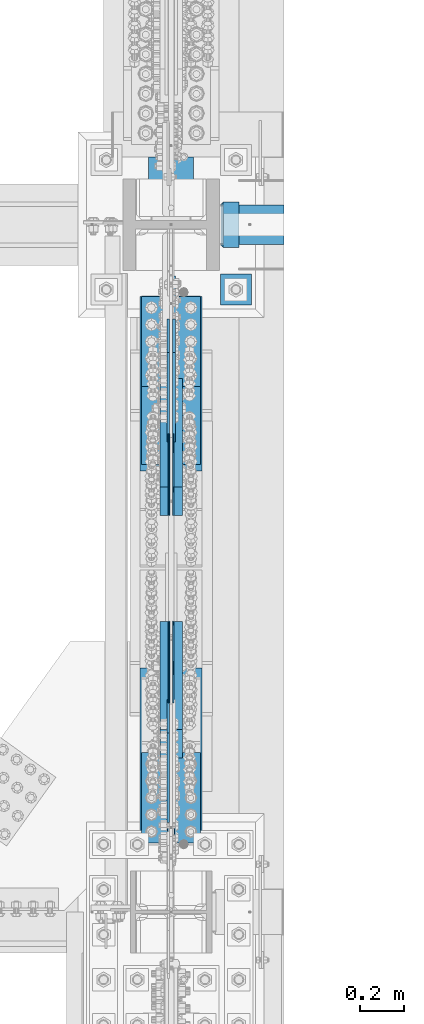
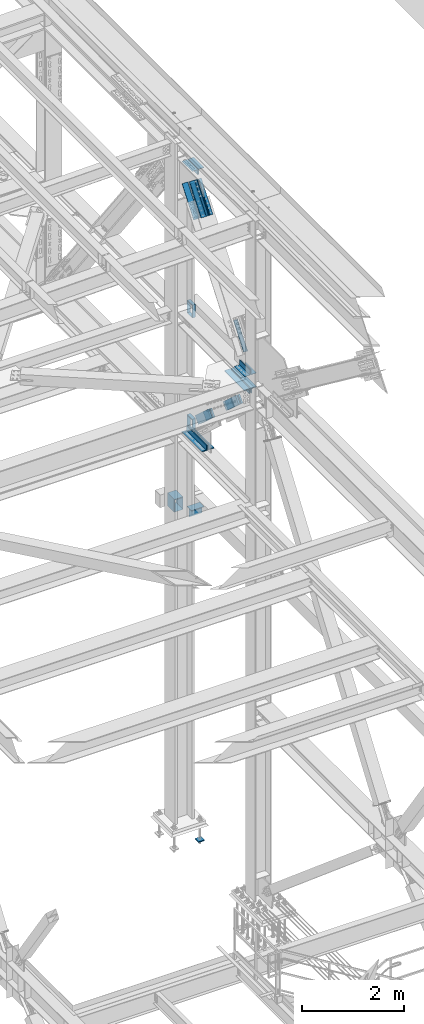
# One storey, part 2592 of 3843: 15 members, 13 beams, 12 elements without a shape of their own.
"""IFC2X3 building model written with IfcOpenShell, lengths in millimetres."""

from ifc_helpers import new_model, si_unit, frame, origin_with_axes, place, context, subcontext, project, spatial, faceted_brep, material, type_object, element, aggregate, save


model = new_model("IFC2X3")

# Units and contexts
model_context = context("Model", 3, precision=1e-05, world=origin_with_axes())
body_context = subcontext(model_context, "Body", "Model", "MODEL_VIEW")
ifc_project = project(units=[si_unit("LENGTHUNIT", "METRE", prefix="MILLI"), si_unit("AREAUNIT", "SQUARE_METRE"), si_unit("VOLUMEUNIT", "CUBIC_METRE"), si_unit("MASSUNIT", "GRAM", prefix="KILO"), si_unit("TIMEUNIT", "SECOND"), si_unit("PLANEANGLEUNIT", "RADIAN"), si_unit("SOLIDANGLEUNIT", "STERADIAN"), si_unit("THERMODYNAMICTEMPERATUREUNIT", "DEGREE_CELSIUS"), si_unit("LUMINOUSINTENSITYUNIT", "LUMEN")], contexts=[model_context])

# Site, building, storey
site_placement = place(None, origin_with_axes())
site = spatial("IfcSite", under=ifc_project, at=site_placement, CompositionType="ELEMENT")
building_placement = place(site_placement, origin_with_axes())
building = spatial("IfcBuilding", under=site, at=building_placement, Name="Undefined", CompositionType="ELEMENT")
storey_placement = place(building_placement, origin_with_axes())
storey = spatial("IfcBuildingStorey", under=building, at=storey_placement, Name="Undefined", CompositionType="ELEMENT", Elevation=0.0)

# Assembly, beams
assembly_1_placement = place(storey_placement, origin_with_axes())
assembly_1 = element("IfcElementAssembly", 1, at=assembly_1_placement, inside=storey, Name="COLUMN", AssemblyPlace="NOTDEFINED", PredefinedType="RIGID_FRAME")
ifc_material_1 = material(Name="STEEL/A992")
beam_type_1 = type_object("IfcBeamType", Name="WT8X18", PredefinedType="NOTDEFINED")
beam_1_placement = place(assembly_1_placement, frame((85866.2875, 28714.7, 37339.5875), z_axis=(0.0, 0.0, 1.0), x_axis=(1.0, 0.0, 0.0)))
beam_1 = element("IfcBeam", 2, at=beam_1_placement, type_object=beam_type_1, material=ifc_material_1, Name="BEAM", ObjectType="WT8X18", context=body_context, shape_type="Brep", body=[
    faceted_brep([(-1.45519152283669e-11, 3.96875, -100.012499999997), (-1.45519152283669e-11, 3.96875, 88.9000000000015), (290.512438964855, 3.96875000066939, 88.9000000000015), (290.512438964855, 3.96875000066939, -100.012499999997), (-2.18278728425503e-10, 88.8999999999942, 88.9000000000015), (290.512438964652, 88.9000000006781, 88.9000000000015), (-2.18278728425503e-10, 88.8999999999942, 100.012499999997), (290.512438964652, 88.9000000006781, 100.012499999997), (2.03726813197136e-10, -88.8999999999942, 100.012499999997), (290.512438965074, -88.8999999993248, 100.012499999997), (2.03726813197136e-10, -88.8999999999942, 88.9000000000015), (290.512438965074, -88.8999999993248, 88.9000000000015), (0.0, -3.96875, 88.9000000000015), (290.51243896487, -3.96874999933061, 88.9000000000015), (0.0, -3.96875, -100.012499999997), (290.51243896487, -3.96874999933061, -100.012499999997)], [[[0, 1, 2, 3]], [[1, 4, 5, 2]], [[4, 6, 7, 5]], [[6, 8, 9, 7]], [[8, 10, 11, 9]], [[10, 12, 13, 11]], [[12, 14, 15, 13]], [[14, 0, 3, 15]], [[5, 7, 9, 11, 13, 15, 3, 2]], [[14, 12, 10, 8, 6, 4, 1, 0]]]),
])
ifc_material_2 = material()
beam_type_2 = type_object("IfcBeamType", Name="HSS12X8X3/8", PredefinedType="NOTDEFINED")
beam_2_placement = place(assembly_1_placement, frame((85648.8, 29019.5, 37592.0), z_axis=(0.0, 0.0, 1.0), x_axis=(0.0, -1.0, 0.0)))
beam_2 = element("IfcBeam", 3, at=beam_2_placement, type_object=beam_type_2, material=ifc_material_2, Name="BEAM", ObjectType="HSS12X8X3/8", context=body_context, shape_type="Brep", body=[
    faceted_brep([(280.193750000006, 92.0749999999971, 142.875), (280.193750000006, 92.0749999999971, -142.875), (270.668750000012, 101.600000000006, -152.400000000001), (270.668750000012, 101.600000000006, 152.400000000001), (280.193750000006, -92.0749999999971, -142.875), (270.668750000012, -101.600000000006, -152.400000000001), (280.193750000006, -92.0749999999971, 142.875), (270.668750000012, -101.600000000006, 152.400000000001), (0.0, 92.0749999999971, 142.875), (0.0, 92.0749999999971, -142.875), (0.0, -92.0749999999971, 142.875), (0.0, -92.0749999999971, -142.875), (0.0, -101.600000000006, -152.400000000001), (0.0, -101.600000000006, 152.400000000001), (0.0, 101.600000000006, 152.400000000001), (0.0, 101.600000000006, -152.400000000001)], [[[0, 1, 2, 3]], [[4, 5, 2, 1]], [[6, 7, 5, 4]], [[8, 9, 1, 0]], [[10, 8, 0, 6]], [[11, 10, 6, 4]], [[9, 11, 4, 1]], [[12, 13, 14, 15], [8, 10, 11, 9]], [[15, 14, 3, 2]], [[12, 15, 2, 5]], [[13, 12, 5, 7]], [[14, 13, 7, 3]], [[0, 3, 7, 6]]]),
])
beam_3_placement = place(assembly_1_placement, frame((85866.2875006762, 28714.7, 39477.95), z_axis=(0.0, 0.0, 1.0), x_axis=(1.0, 0.0, 0.0)))
beam_3 = element("IfcBeam", 4, at=beam_3_placement, type_object=beam_type_2, material=ifc_material_2, Name="BEAM", ObjectType="HSS12X8X3/8", context=body_context, shape_type="Brep", body=[
    faceted_brep([(15.8750001309381, 101.600000000006, 152.399999999972), (15.8749984899478, 101.600000000006, -152.400000000031), (6.35000000002037, 92.0749999999971, -142.875), (6.35000000002037, 92.0749999999971, 142.875), (15.8749984899478, -101.600000000006, -152.400000000031), (6.35000000002037, -92.0749999999971, -142.875), (15.8750001044536, -101.600000052975, 152.399999973481), (6.35000000002037, -92.0749999999971, 142.875), (87.3124999991851, -101.600000000006, 152.39999999987), (87.3124999991851, 101.600000000006, 152.39999999987), (87.312500000975, -101.600000000006, -152.400000000125), (87.312500000975, 101.600000000006, -152.400000000125), (87.3124999992433, -92.0749999999971, 142.874999999876), (87.3124999992433, 92.0749999999971, 142.874999999876), (87.3125000009022, 92.0749999999971, -142.875000000124), (87.3125000009022, -92.0749999999971, -142.875000000124)], [[[0, 1, 2, 3]], [[4, 5, 2, 1]], [[6, 7, 5, 4]], [[8, 9, 0, 6]], [[10, 8, 6, 4]], [[11, 10, 4, 1]], [[9, 11, 1, 0]], [[8, 10, 11, 9], [12, 13, 14, 15]], [[14, 13, 3, 2]], [[15, 14, 2, 5]], [[12, 15, 5, 7]], [[13, 12, 7, 3]], [[0, 3, 7, 6]]]),
])
beam_4_placement = place(assembly_1_placement, frame((85866.2875007094, 28714.7, 42214.8), z_axis=(0.0, 0.0, 1.0), x_axis=(1.0, 0.0, 0.0)))
beam_4 = element("IfcBeam", 5, at=beam_4_placement, type_object=beam_type_2, material=ifc_material_2, Name="BEAM", ObjectType="HSS12X8X3/8", context=body_context, shape_type="Brep", body=[
    faceted_brep([(15.8750001309381, 101.600000000006, 152.399999999972), (15.8749984899478, 101.600000000006, -152.400000000031), (6.35000000002037, 92.0749999999971, -142.875), (6.35000000002037, 92.0749999999971, 142.875), (15.8749984899478, -101.600000000006, -152.400000000031), (6.35000000002037, -92.0749999999971, -142.875), (15.8750001044536, -101.600000052975, 152.399999973481), (6.35000000002037, -92.0749999999971, 142.875), (87.3124999991851, -101.600000000006, 152.39999999987), (87.3124999991851, 101.600000000006, 152.39999999987), (87.312500000975, -101.600000000006, -152.400000000125), (87.312500000975, 101.600000000006, -152.400000000125), (87.3124999992433, -92.0749999999971, 142.874999999876), (87.3124999992433, 92.0749999999971, 142.874999999876), (87.3125000009022, 92.0749999999971, -142.875000000124), (87.3125000009022, -92.0749999999971, -142.875000000124)], [[[0, 1, 2, 3]], [[4, 5, 2, 1]], [[6, 7, 5, 4]], [[8, 9, 0, 6]], [[10, 8, 6, 4]], [[11, 10, 4, 1]], [[9, 11, 1, 0]], [[8, 10, 11, 9], [12, 13, 14, 15]], [[14, 13, 3, 2]], [[15, 14, 2, 5]], [[12, 15, 5, 7]], [[13, 12, 7, 3]], [[0, 3, 7, 6]]]),
])
aggregate(assembly_1, [beam_1, beam_2, beam_3, beam_4])

# Assembly, members
assembly_2_placement = place(storey_placement, origin_with_axes())
assembly_2 = element("IfcElementAssembly", 6, at=assembly_2_placement, inside=storey, AssemblyPlace="NOTDEFINED", PredefinedType="RIGID_FRAME")
ifc_material_3 = material(Name="STEEL/A572-50")
member_type_1 = type_object("IfcMemberType", PredefinedType="NOTDEFINED")
member_1_placement = place(assembly_2_placement, frame((85680.5500000244, 27956.6025375945, 40116.8944140801), z_axis=(0.0, -0.672974507774428, -0.73966567575207), x_axis=(0.0, -0.739665675752071, 0.672974507774427)))
member_1 = element("IfcMember", 7, at=member_1_placement, type_object=member_type_1, material=ifc_material_3, Name="PLATE", context=body_context, shape_type="Brep", body=[
    faceted_brep([(1.16415321826935e-10, 19.0500000000029, -95.2500000001601), (-1.16415321826935e-10, 19.0500000000029, 95.2500000001601), (660.400000008245, 19.0500000000029, 95.2500000025429), (660.400000007954, 19.0500000000029, -95.2499999980901), (-1.16415321826935e-10, -19.0500000000029, 95.2500000001601), (660.400000008245, -19.0500000000029, 95.2500000025429), (1.16415321826935e-10, -19.0500000000029, -95.2500000001601), (660.400000007954, -19.0500000000029, -95.2499999980901)], [[[0, 1, 2, 3]], [[1, 4, 5, 2]], [[4, 6, 7, 5]], [[6, 0, 3, 7]], [[5, 7, 3, 2]], [[6, 4, 1, 0]]]),
])
member_2_placement = place(assembly_2_placement, frame((85617.0500000244, 27956.6025375945, 40116.8944140801), z_axis=(0.0, -0.672974507774428, -0.73966567575207), x_axis=(0.0, -0.739665675752071, 0.672974507774427)))
member_2 = element("IfcMember", 8, at=member_2_placement, type_object=member_type_1, material=ifc_material_3, Name="PLATE", context=body_context, shape_type="Brep", body=[
    faceted_brep([(1.16415321826935e-10, 19.0500000000029, -95.2500000001601), (-1.16415321826935e-10, 19.0500000000029, 95.2500000001601), (660.400000008245, 19.0500000000029, 95.2500000025429), (660.400000007954, 19.0500000000029, -95.2499999980901), (-1.16415321826935e-10, -19.0500000000029, 95.2500000001601), (660.400000008245, -19.0500000000029, 95.2500000025429), (1.16415321826935e-10, -19.0500000000029, -95.2500000001601), (660.400000007954, -19.0500000000029, -95.2499999980901)], [[[0, 1, 2, 3]], [[1, 4, 5, 2]], [[4, 6, 7, 5]], [[6, 0, 3, 7]], [[5, 7, 3, 2]], [[6, 4, 1, 0]]]),
])
member_3_placement = place(assembly_2_placement, frame((85680.5500000244, 26374.2859692125, 41556.5430940823), z_axis=(0.0, 0.672974507774428, 0.73966567575207), x_axis=(0.0, 0.739665675752074, -0.672974507774424)))
member_3 = element("IfcMember", 9, at=member_3_placement, type_object=member_type_1, material=ifc_material_3, Name="PLATE", context=body_context, shape_type="Brep", body=[
    faceted_brep([(1.16415321826935e-10, 19.0500000000029, -95.2500000001601), (-1.16415321826935e-10, 19.0500000000029, 95.2500000001601), (660.400000008245, 19.0500000000029, 95.2500000025429), (660.400000007954, 19.0500000000029, -95.2499999980901), (-1.16415321826935e-10, -19.0500000000029, 95.2500000001601), (660.400000008245, -19.0500000000029, 95.2500000025429), (1.16415321826935e-10, -19.0500000000029, -95.2500000001601), (660.400000007954, -19.0500000000029, -95.2499999980901)], [[[0, 1, 2, 3]], [[1, 4, 5, 2]], [[4, 6, 7, 5]], [[6, 0, 3, 7]], [[5, 7, 3, 2]], [[6, 4, 1, 0]]]),
])
member_4_placement = place(assembly_2_placement, frame((85617.0500000244, 26374.2859692125, 41556.5430940823), z_axis=(0.0, 0.672974507774428, 0.73966567575207), x_axis=(0.0, 0.739665675752074, -0.672974507774424)))
member_4 = element("IfcMember", 10, at=member_4_placement, type_object=member_type_1, material=ifc_material_3, Name="PLATE", context=body_context, shape_type="Brep", body=[
    faceted_brep([(1.16415321826935e-10, 19.0500000000029, -95.2500000001601), (-1.16415321826935e-10, 19.0500000000029, 95.2500000001601), (660.400000008245, 19.0500000000029, 95.2500000025429), (660.400000007954, 19.0500000000029, -95.2499999980901), (-1.16415321826935e-10, -19.0500000000029, 95.2500000001601), (660.400000008245, -19.0500000000029, 95.2500000025429), (1.16415321826935e-10, -19.0500000000029, -95.2500000001601), (660.400000007954, -19.0500000000029, -95.2499999980901)], [[[0, 1, 2, 3]], [[1, 4, 5, 2]], [[4, 6, 7, 5]], [[6, 0, 3, 7]], [[5, 7, 3, 2]], [[6, 4, 1, 0]]]),
])

assembly_3_placement = place(storey_placement, origin_with_axes())
assembly_3 = element("IfcElementAssembly", 11, at=assembly_3_placement, inside=storey, AssemblyPlace="NOTDEFINED", PredefinedType="RIGID_FRAME")
member_type_2 = type_object("IfcMemberType", Name="L5X5X1/2", PredefinedType="NOTDEFINED")
member_5_placement = place(assembly_3_placement, frame((85718.6500000203, 28432.895159196, 45510.7300220874), z_axis=(0.0, 0.792438093282071, -0.609952349217114), x_axis=(0.0, -0.609952349217112, -0.792438093282072)))
member_5 = element("IfcMember", 12, at=member_5_placement, type_object=member_type_2, material=ifc_material_3, Name="ANGLE", ObjectType="L5X5X1/2", context=body_context, shape_type="Brep", body=[
    faceted_brep([(-1.01863406598568e-10, 63.5, -63.5000000002037), (1.01863406598568e-10, 63.5, 63.5000000002074), (749.300000016152, 63.5, 63.4999999992142), (749.300000016028, 63.5, -63.5000000006548), (1.01863406598568e-10, 50.8000000000029, 63.5000000002074), (749.300000016152, 50.8000000000029, 63.4999999992142), (0.0, 50.8000000000029, -50.8000000000029), (749.30000001605, 50.8000000000029, -50.8000000006577), (-7.27595761418343e-11, -63.5, -50.8000000001666), (749.30000001605, -63.5, -50.8000000006577), (-1.01863406598568e-10, -63.5, -63.5000000002037), (749.300000016028, -63.5, -63.5000000006548)], [[[0, 1, 2, 3]], [[1, 4, 5, 2]], [[4, 6, 7, 5]], [[6, 8, 9, 7]], [[8, 10, 11, 9]], [[10, 0, 3, 11]], [[5, 7, 9, 11, 3, 2]], [[10, 8, 6, 4, 1, 0]]]),
])
member_6_placement = place(assembly_3_placement, frame((85718.6500000203, 27593.4272401154, 45211.3191625252), z_axis=(0.0, -0.79243809328207, 0.609952349217115), x_axis=(0.0, 0.60995234921711, 0.792438093282074)))
member_6 = element("IfcMember", 13, at=member_6_placement, type_object=member_type_2, material=ifc_material_3, Name="ANGLE", ObjectType="L5X5X1/2", context=body_context, shape_type="Brep", body=[
    faceted_brep([(-1.01863406598568e-10, 63.5, -63.5000000002037), (1.01863406598568e-10, 63.5, 63.5000000002074), (749.300000016152, 63.5, 63.4999999992142), (749.300000016028, 63.5, -63.5000000006548), (1.01863406598568e-10, 50.8000000000029, 63.5000000002074), (749.300000016152, 50.8000000000029, 63.4999999992142), (0.0, 50.8000000000029, -50.8000000000029), (749.30000001605, 50.8000000000029, -50.8000000006577), (-7.27595761418343e-11, -63.5, -50.8000000001666), (749.30000001605, -63.5, -50.8000000006577), (-1.01863406598568e-10, -63.5, -63.5000000002037), (749.300000016028, -63.5, -63.5000000006548)], [[[0, 1, 2, 3]], [[1, 4, 5, 2]], [[4, 6, 7, 5]], [[6, 8, 9, 7]], [[8, 10, 11, 9]], [[10, 0, 3, 11]], [[5, 7, 9, 11, 3, 2]], [[10, 8, 6, 4, 1, 0]]]),
])
member_7_placement = place(assembly_3_placement, frame((85578.9500000203, 27975.8578639315, 44916.956158795), z_axis=(0.0, 0.792438093282071, -0.609952349217114), x_axis=(0.0, 0.60995234921711, 0.792438093282074)))
member_7 = element("IfcMember", 14, at=member_7_placement, type_object=member_type_2, material=ifc_material_3, Name="ANGLE", ObjectType="L5X5X1/2", context=body_context, shape_type="Brep", body=[
    faceted_brep([(-1.01863406598568e-10, 63.5, -63.5000000002037), (1.01863406598568e-10, 63.5, 63.5000000002074), (749.300000016152, 63.5, 63.4999999992142), (749.300000016028, 63.5, -63.5000000006548), (1.01863406598568e-10, 50.8000000000029, 63.5000000002074), (749.300000016152, 50.8000000000029, 63.4999999992142), (0.0, 50.8000000000029, -50.8000000000029), (749.30000001605, 50.8000000000029, -50.8000000006577), (-7.27595761418343e-11, -63.5, -50.8000000001666), (749.30000001605, -63.5, -50.8000000006577), (-1.01863406598568e-10, -63.5, -63.5000000002037), (749.300000016028, -63.5, -63.5000000006548)], [[[0, 1, 2, 3]], [[1, 4, 5, 2]], [[4, 6, 7, 5]], [[6, 8, 9, 7]], [[8, 10, 11, 9]], [[10, 0, 3, 11]], [[5, 7, 9, 11, 3, 2]], [[10, 8, 6, 4, 1, 0]]]),
])
member_8_placement = place(assembly_3_placement, frame((85578.9500000203, 28050.4645353799, 45805.0930258176), z_axis=(0.0, -0.79243809328207, 0.609952349217115), x_axis=(0.0, -0.609952349217112, -0.792438093282072)))
member_8 = element("IfcMember", 15, at=member_8_placement, type_object=member_type_2, material=ifc_material_3, Name="ANGLE", ObjectType="L5X5X1/2", context=body_context, shape_type="Brep", body=[
    faceted_brep([(-1.01863406598568e-10, 63.5, -63.5000000002037), (1.01863406598568e-10, 63.5, 63.5000000002074), (749.300000016152, 63.5, 63.4999999992142), (749.300000016028, 63.5, -63.5000000006548), (1.01863406598568e-10, 50.8000000000029, 63.5000000002074), (749.300000016152, 50.8000000000029, 63.4999999992142), (0.0, 50.8000000000029, -50.8000000000029), (749.30000001605, 50.8000000000029, -50.8000000006577), (-7.27595761418343e-11, -63.5, -50.8000000001666), (749.30000001605, -63.5, -50.8000000006577), (-1.01863406598568e-10, -63.5, -63.5000000002037), (749.300000016028, -63.5, -63.5000000006548)], [[[0, 1, 2, 3]], [[1, 4, 5, 2]], [[4, 6, 7, 5]], [[6, 8, 9, 7]], [[8, 10, 11, 9]], [[10, 0, 3, 11]], [[5, 7, 9, 11, 3, 2]], [[10, 8, 6, 4, 1, 0]]]),
])

# Member
member_type_3 = type_object("IfcMemberType", PredefinedType="NOTDEFINED")
member_9_placement = place(assembly_2_placement, frame((85658.3250000244, 27707.6680544176, 40343.3839846709), z_axis=(0.0, -0.672974507774428, -0.73966567575207), x_axis=(0.0, -0.739665675752071, 0.672974507774427)))
member_9 = element("IfcMember", 16, at=member_9_placement, type_object=member_type_3, material=ifc_material_3, Name="PLATE", context=body_context, shape_type="Brep", body=[
    faceted_brep([(0.0, 3.17499999999927, -95.25), (-2.44140610448085e-05, 3.17500000000291, 95.2499999999927), (323.850000004109, 3.17500000000291, 95.2500000014152), (323.850000003833, 3.17500000000291, -95.2499999992106), (0.0, -3.17499999999927, 95.25), (323.850000004109, -3.17500000000291, 95.2500000014152), (0.0, -3.17499999999927, -95.25), (323.850000003833, -3.17500000000291, -95.2499999992106)], [[[0, 1, 2, 3]], [[1, 4, 5, 2]], [[4, 6, 7, 5]], [[6, 0, 3, 7]], [[5, 7, 3, 2]], [[6, 4, 1, 0]]]),
])

member_10_placement = place(assembly_2_placement, frame((85639.2750000244, 27707.6680544176, 40343.3839846709), z_axis=(0.0, -0.672974507774428, -0.73966567575207), x_axis=(0.0, -0.739665675752071, 0.672974507774427)))
member_10 = element("IfcMember", 17, at=member_10_placement, type_object=member_type_3, material=ifc_material_3, Name="PLATE", context=body_context, shape_type="Brep", body=[
    faceted_brep([(0.0, 3.17499999999927, -95.25), (-2.44140610448085e-05, 3.17500000000291, 95.2499999999927), (323.850000004109, 3.17500000000291, 95.2500000014152), (323.850000003833, 3.17500000000291, -95.2499999992106), (0.0, -3.17499999999927, 95.25), (323.850000004109, -3.17500000000291, 95.2500000014152), (0.0, -3.17499999999927, -95.25), (323.850000003833, -3.17500000000291, -95.2499999992106)], [[[0, 1, 2, 3]], [[1, 4, 5, 2]], [[4, 6, 7, 5]], [[6, 0, 3, 7]], [[5, 7, 3, 2]], [[6, 4, 1, 0]]]),
])

member_11_placement = place(assembly_2_placement, frame((85658.3250000244, 26623.2204523893, 41330.0535234915), z_axis=(0.0, 0.672974507774428, 0.73966567575207), x_axis=(0.0, 0.739665675752074, -0.672974507774424)))
member_11 = element("IfcMember", 18, at=member_11_placement, type_object=member_type_3, material=ifc_material_3, Name="PLATE", context=body_context, shape_type="Brep", body=[
    faceted_brep([(0.0, 3.17499999999927, -95.25), (-2.44140610448085e-05, 3.17500000000291, 95.2499999999927), (323.850000004109, 3.17500000000291, 95.2500000014152), (323.850000003833, 3.17500000000291, -95.2499999992106), (0.0, -3.17499999999927, 95.25), (323.850000004109, -3.17500000000291, 95.2500000014152), (0.0, -3.17499999999927, -95.25), (323.850000003833, -3.17500000000291, -95.2499999992106)], [[[0, 1, 2, 3]], [[1, 4, 5, 2]], [[4, 6, 7, 5]], [[6, 0, 3, 7]], [[5, 7, 3, 2]], [[6, 4, 1, 0]]]),
])

member_12_placement = place(assembly_2_placement, frame((85639.2750000244, 26623.2204523893, 41330.0535234915), z_axis=(0.0, 0.672974507774428, 0.73966567575207), x_axis=(0.0, 0.739665675752074, -0.672974507774424)))
member_12 = element("IfcMember", 19, at=member_12_placement, type_object=member_type_3, material=ifc_material_3, Name="PLATE", context=body_context, shape_type="Brep", body=[
    faceted_brep([(0.0, 3.17499999999927, -95.25), (-2.44140610448085e-05, 3.17500000000291, 95.2499999999927), (323.850000004109, 3.17500000000291, 95.2500000014152), (323.850000003833, 3.17500000000291, -95.2499999992106), (0.0, -3.17499999999927, 95.25), (323.850000004109, -3.17500000000291, 95.2500000014152), (0.0, -3.17499999999927, -95.25), (323.850000003833, -3.17500000000291, -95.2499999992106)], [[[0, 1, 2, 3]], [[1, 4, 5, 2]], [[4, 6, 7, 5]], [[6, 0, 3, 7]], [[5, 7, 3, 2]], [[6, 4, 1, 0]]]),
])

aggregate(assembly_2, [member_1, member_9, member_10, member_2, member_3, member_11, member_12, member_4])

# Assembly, beam
assembly_4_placement = place(storey_placement, origin_with_axes())
assembly_4 = element("IfcElementAssembly", 20, at=assembly_4_placement, inside=storey, Name="ANGLE", AssemblyPlace="NOTDEFINED", PredefinedType="RIGID_FRAME")
beam_type_3 = type_object("IfcBeamType", Name="L5X5X3/4", PredefinedType="NOTDEFINED")
beam_5_placement = place(assembly_4_placement, frame((85725.0000000257, 27604.2437499993, 39649.3999999958), z_axis=(0.0, 0.0, 1.0), x_axis=(0.0, 1.0, 0.0)))
beam_5 = element("IfcBeam", 21, at=beam_5_placement, type_object=beam_type_3, material=ifc_material_3, Name="ANGLE", ObjectType="L5X5X3/4", context=body_context, shape_type="Brep", body=[
    faceted_brep([(-1.01863406598568e-10, 63.5, -63.5000000002037), (1.01863406598568e-10, 63.5, 63.5000000002074), (787.399999999994, 63.5, 63.5), (787.399999999994, 63.5, -63.5), (0.0, 44.4499999999971, 63.5), (787.399999999994, 44.4499999999971, 63.5), (-3.63797880709171e-12, 44.4499999999971, -44.4500000000007), (787.399999999994, 44.4499999999971, -44.4499999999971), (0.0, -63.5, -44.4499999999971), (787.399999999994, -63.5, -44.4499999999971), (-1.01863406598568e-10, -63.5, -63.5000000002037), (787.399999999994, -63.5, -63.5)], [[[0, 1, 2, 3]], [[1, 4, 5, 2]], [[4, 6, 7, 5]], [[6, 8, 9, 7]], [[8, 10, 11, 9]], [[10, 0, 3, 11]], [[5, 7, 9, 11, 3, 2]], [[10, 8, 6, 4, 1, 0]]]),
])
aggregate(assembly_4, [beam_5])

assembly_5_placement = place(storey_placement, origin_with_axes())
assembly_5 = element("IfcElementAssembly", 22, at=assembly_5_placement, inside=storey, Name="ANGLE", AssemblyPlace="NOTDEFINED", PredefinedType="RIGID_FRAME")
beam_6_placement = place(assembly_5_placement, frame((85572.6000000232, 28391.6437499993, 39649.3999999963), z_axis=(0.0, 0.0, 1.0), x_axis=(0.0, -1.0, 0.0)))
beam_6 = element("IfcBeam", 23, at=beam_6_placement, type_object=beam_type_3, material=ifc_material_3, Name="ANGLE", ObjectType="L5X5X3/4", context=body_context, shape_type="Brep", body=[
    faceted_brep([(-1.01863406598568e-10, 63.5, -63.5000000002037), (1.01863406598568e-10, 63.5, 63.5000000002074), (787.399999999994, 63.5, 63.5), (787.399999999994, 63.5, -63.5), (0.0, 44.4499999999971, 63.5), (787.399999999994, 44.4499999999971, 63.5), (-3.63797880709171e-12, 44.4499999999971, -44.4500000000007), (787.399999999994, 44.4499999999971, -44.4499999999971), (0.0, -63.5, -44.4499999999971), (787.399999999994, -63.5, -44.4499999999971), (-1.01863406598568e-10, -63.5, -63.5000000002037), (787.399999999994, -63.5, -63.5)], [[[0, 1, 2, 3]], [[1, 4, 5, 2]], [[4, 6, 7, 5]], [[6, 8, 9, 7]], [[8, 10, 11, 9]], [[10, 0, 3, 11]], [[5, 7, 9, 11, 3, 2]], [[10, 8, 6, 4, 1, 0]]]),
])
aggregate(assembly_5, [beam_6])

assembly_6_placement = place(storey_placement, origin_with_axes())
assembly_6 = element("IfcElementAssembly", 24, at=assembly_6_placement, inside=storey, Name="ANGLE", AssemblyPlace="NOTDEFINED", PredefinedType="RIGID_FRAME")
beam_7_placement = place(assembly_6_placement, frame((85725.0000000244, 26715.24375, 42024.2999999997), z_axis=(0.0, 0.0, -1.0), x_axis=(0.0, -1.0, 0.0)))
beam_7 = element("IfcBeam", 25, at=beam_7_placement, type_object=beam_type_3, material=ifc_material_3, Name="ANGLE", ObjectType="L5X5X3/4", context=body_context, shape_type="Brep", body=[
    faceted_brep([(-1.01863406598568e-10, 63.5, -63.5000000002037), (1.01863406598568e-10, 63.5, 63.5000000002074), (787.399999999994, 63.5, 63.5), (787.399999999994, 63.5, -63.5), (0.0, 44.4499999999971, 63.5), (787.399999999994, 44.4499999999971, 63.5), (-3.63797880709171e-12, 44.4499999999971, -44.4500000000007), (787.399999999994, 44.4499999999971, -44.4499999999971), (0.0, -63.5, -44.4499999999971), (787.399999999994, -63.5, -44.4499999999971), (-1.01863406598568e-10, -63.5, -63.5000000002037), (787.399999999994, -63.5, -63.5)], [[[0, 1, 2, 3]], [[1, 4, 5, 2]], [[4, 6, 7, 5]], [[6, 8, 9, 7]], [[8, 10, 11, 9]], [[10, 0, 3, 11]], [[5, 7, 9, 11, 3, 2]], [[10, 8, 6, 4, 1, 0]]]),
])
aggregate(assembly_6, [beam_7])

assembly_7_placement = place(storey_placement, origin_with_axes())
assembly_7 = element("IfcElementAssembly", 26, at=assembly_7_placement, inside=storey, Name="ANGLE", AssemblyPlace="NOTDEFINED", PredefinedType="RIGID_FRAME")
beam_8_placement = place(assembly_7_placement, frame((85572.6000000257, 25927.84375, 42024.3000000003), z_axis=(0.0, 0.0, -1.0), x_axis=(0.0, 1.0, 0.0)))
beam_8 = element("IfcBeam", 27, at=beam_8_placement, type_object=beam_type_3, material=ifc_material_3, Name="ANGLE", ObjectType="L5X5X3/4", context=body_context, shape_type="Brep", body=[
    faceted_brep([(-1.01863406598568e-10, 63.5, -63.5000000002037), (1.01863406598568e-10, 63.5, 63.5000000002074), (787.399999999994, 63.5, 63.5), (787.399999999994, 63.5, -63.5), (0.0, 44.4499999999971, 63.5), (787.399999999994, 44.4499999999971, 63.5), (-3.63797880709171e-12, 44.4499999999971, -44.4500000000007), (787.399999999994, 44.4499999999971, -44.4499999999971), (0.0, -63.5, -44.4499999999971), (787.399999999994, -63.5, -44.4499999999971), (-1.01863406598568e-10, -63.5, -63.5000000002037), (787.399999999994, -63.5, -63.5)], [[[0, 1, 2, 3]], [[1, 4, 5, 2]], [[4, 6, 7, 5]], [[6, 8, 9, 7]], [[8, 10, 11, 9]], [[10, 0, 3, 11]], [[5, 7, 9, 11, 3, 2]], [[10, 8, 6, 4, 1, 0]]]),
])
aggregate(assembly_7, [beam_8])

# Member
member_type_4 = type_object("IfcMemberType", PredefinedType="NOTDEFINED")
member_13_placement = place(assembly_3_placement, frame((85661.5000000203, 28214.5674653655, 45622.6876507063), z_axis=(0.0, 0.792438093282071, -0.609952349217114), x_axis=(0.0, -0.609952349217112, -0.792438093282072)))
member_13 = element("IfcMember", 28, at=member_13_placement, type_object=member_type_4, material=ifc_material_3, Name="PLATE", context=body_context, shape_type="Brep", body=[
    faceted_brep([(-8.00355337560177e-11, 6.35000000000582, -95.2499999999127), (9.45874489843845e-11, 6.35000000000582, 95.2499999998981), (660.399999994639, 6.35000000000582, 95.249999999287), (660.399999994457, 6.35000000000582, -95.2500000005239), (9.45874489843845e-11, -6.35000000000582, 95.2499999998981), (660.399999994639, -6.35000000000582, 95.249999999287), (-8.00355337560177e-11, -6.35000000000582, -95.2499999999127), (660.399999994457, -6.35000000000582, -95.2500000005239)], [[[0, 1, 2, 3]], [[1, 4, 5, 2]], [[4, 6, 7, 5]], [[6, 0, 3, 7]], [[5, 7, 3, 2]], [[6, 4, 1, 0]]]),
])

member_14_placement = place(assembly_3_placement, frame((85636.1000000203, 28214.5674653655, 45622.6876507063), z_axis=(0.0, 0.792438093282071, -0.609952349217114), x_axis=(0.0, -0.609952349217112, -0.792438093282072)))
member_14 = element("IfcMember", 29, at=member_14_placement, type_object=member_type_4, material=ifc_material_3, Name="PLATE", context=body_context, shape_type="Brep", body=[
    faceted_brep([(-8.00355337560177e-11, 6.35000000000582, -95.2499999999127), (9.45874489843845e-11, 6.35000000000582, 95.2499999998981), (660.399999994639, 6.35000000000582, 95.249999999287), (660.399999994457, 6.35000000000582, -95.2500000005239), (9.45874489843845e-11, -6.35000000000582, 95.2499999998981), (660.399999994639, -6.35000000000582, 95.249999999287), (-8.00355337560177e-11, -6.35000000000582, -95.2499999999127), (660.399999994457, -6.35000000000582, -95.2500000005239)], [[[0, 1, 2, 3]], [[1, 4, 5, 2]], [[4, 6, 7, 5]], [[6, 0, 3, 7]], [[5, 7, 3, 2]], [[6, 4, 1, 0]]]),
])

member_15_placement = place(assembly_3_placement, frame((85636.1000000203, 26095.2598207584, 42869.3248492896), z_axis=(0.0, -0.79243809328207, 0.609952349217115), x_axis=(0.0, 0.60995234921711, 0.792438093282074)))
member_15 = element("IfcMember", 30, at=member_15_placement, type_object=member_type_4, material=ifc_material_3, Name="PLATE", context=body_context, shape_type="Brep", body=[
    faceted_brep([(-8.00355337560177e-11, 6.35000000000582, -95.2499999999127), (9.45874489843845e-11, 6.35000000000582, 95.2499999998981), (660.399999994639, 6.35000000000582, 95.249999999287), (660.399999994457, 6.35000000000582, -95.2500000005239), (9.45874489843845e-11, -6.35000000000582, 95.2499999998981), (660.399999994639, -6.35000000000582, 95.249999999287), (-8.00355337560177e-11, -6.35000000000582, -95.2499999999127), (660.399999994457, -6.35000000000582, -95.2500000005239)], [[[0, 1, 2, 3]], [[1, 4, 5, 2]], [[4, 6, 7, 5]], [[6, 0, 3, 7]], [[5, 7, 3, 2]], [[6, 4, 1, 0]]]),
])

aggregate(assembly_3, [member_5, member_6, member_13, member_7, member_8, member_14, member_15])

# Assembly, beam
assembly_8_placement = place(storey_placement, origin_with_axes())
assembly_8 = element("IfcElementAssembly", 31, at=assembly_8_placement, inside=storey, Name="ANGLE", AssemblyPlace="NOTDEFINED", PredefinedType="RIGID_FRAME")
beam_type_4 = type_object("IfcBeamType", Name="L5X5X3/8", PredefinedType="NOTDEFINED")
beam_9_placement = place(assembly_8_placement, frame((85718.6500000203, 28391.6437499934, 46024.7999999988), z_axis=(0.0, 0.0, -1.0), x_axis=(0.0, -1.0, 0.0)))
beam_9 = element("IfcBeam", 32, at=beam_9_placement, type_object=beam_type_4, material=ifc_material_3, Name="ANGLE", ObjectType="L5X5X3/8", context=body_context, shape_type="Brep", body=[
    faceted_brep([(-1.01863406598568e-10, 63.5, -63.5000000002037), (1.01863406598568e-10, 63.5, 63.5000000002074), (406.400000000009, 63.5, 63.5), (406.400000000009, 63.5, -63.5), (0.0, 53.9750000000058, 63.5), (406.400000000009, 53.9750000000058, 63.5), (0.0, 53.9750000000058, -53.9749999999985), (406.400000000009, 53.9750000000058, -53.9749999999985), (0.0, -63.5, -53.9749999999985), (406.400000000009, -63.5, -53.9749999999985), (-1.01863406598568e-10, -63.5, -63.5000000002037), (406.400000000009, -63.5, -63.5)], [[[0, 1, 2, 3]], [[1, 4, 5, 2]], [[4, 6, 7, 5]], [[6, 8, 9, 7]], [[8, 10, 11, 9]], [[10, 0, 3, 11]], [[5, 7, 9, 11, 3, 2]], [[10, 8, 6, 4, 1, 0]]]),
])
aggregate(assembly_8, [beam_9])

assembly_9_placement = place(storey_placement, origin_with_axes())
assembly_9 = element("IfcElementAssembly", 33, at=assembly_9_placement, inside=storey, Name="ANGLE", AssemblyPlace="NOTDEFINED", PredefinedType="RIGID_FRAME")
beam_10_placement = place(assembly_9_placement, frame((85578.9500000203, 27985.2437499934, 46024.7999999994), z_axis=(0.0, 0.0, -1.0), x_axis=(0.0, 1.0, 0.0)))
beam_10 = element("IfcBeam", 34, at=beam_10_placement, type_object=beam_type_4, material=ifc_material_3, Name="ANGLE", ObjectType="L5X5X3/8", context=body_context, shape_type="Brep", body=[
    faceted_brep([(-1.01863406598568e-10, 63.5, -63.5000000002037), (1.01863406598568e-10, 63.5, 63.5000000002074), (406.400000000009, 63.5, 63.5), (406.400000000009, 63.5, -63.5), (0.0, 53.9750000000058, 63.5), (406.400000000009, 53.9750000000058, 63.5), (0.0, 53.9750000000058, -53.9749999999985), (406.400000000009, 53.9750000000058, -53.9749999999985), (0.0, -63.5, -53.9749999999985), (406.400000000009, -63.5, -53.9749999999985), (-1.01863406598568e-10, -63.5, -63.5000000002037), (406.400000000009, -63.5, -63.5)], [[[0, 1, 2, 3]], [[1, 4, 5, 2]], [[4, 6, 7, 5]], [[6, 8, 9, 7]], [[8, 10, 11, 9]], [[10, 0, 3, 11]], [[5, 7, 9, 11, 3, 2]], [[10, 8, 6, 4, 1, 0]]]),
])
aggregate(assembly_9, [beam_10])

assembly_10_placement = place(storey_placement, origin_with_axes())
assembly_10 = element("IfcElementAssembly", 35, at=assembly_10_placement, inside=storey, Name="ANGLE", AssemblyPlace="NOTDEFINED", PredefinedType="RIGID_FRAME")
beam_11_placement = place(assembly_10_placement, frame((85718.6500000215, 25927.8437499997, 42468.8), z_axis=(0.0, 0.0, 1.0), x_axis=(0.0, 1.0, 0.0)))
beam_11 = element("IfcBeam", 36, at=beam_11_placement, type_object=beam_type_4, material=ifc_material_3, Name="ANGLE", ObjectType="L5X5X3/8", context=body_context, shape_type="Brep", body=[
    faceted_brep([(-1.01863406598568e-10, 63.5, -63.5000000002037), (1.01863406598568e-10, 63.5, 63.5000000002074), (406.400000000009, 63.5, 63.5), (406.400000000009, 63.5, -63.5), (0.0, 53.9750000000058, 63.5), (406.400000000009, 53.9750000000058, 63.5), (0.0, 53.9750000000058, -53.9749999999985), (406.400000000009, 53.9750000000058, -53.9749999999985), (0.0, -63.5, -53.9749999999985), (406.400000000009, -63.5, -53.9749999999985), (-1.01863406598568e-10, -63.5, -63.5000000002037), (406.400000000009, -63.5, -63.5)], [[[0, 1, 2, 3]], [[1, 4, 5, 2]], [[4, 6, 7, 5]], [[6, 8, 9, 7]], [[8, 10, 11, 9]], [[10, 0, 3, 11]], [[5, 7, 9, 11, 3, 2]], [[10, 8, 6, 4, 1, 0]]]),
])
aggregate(assembly_10, [beam_11])

assembly_11_placement = place(storey_placement, origin_with_axes())
assembly_11 = element("IfcElementAssembly", 37, at=assembly_11_placement, inside=storey, Name="ANGLE", AssemblyPlace="NOTDEFINED", PredefinedType="RIGID_FRAME")
beam_12_placement = place(assembly_11_placement, frame((85578.9500000203, 26334.2437499997, 42468.8000000005), z_axis=(0.0, 0.0, 1.0), x_axis=(0.0, -1.0, 0.0)))
beam_12 = element("IfcBeam", 38, at=beam_12_placement, type_object=beam_type_4, material=ifc_material_3, Name="ANGLE", ObjectType="L5X5X3/8", context=body_context, shape_type="Brep", body=[
    faceted_brep([(-1.01863406598568e-10, 63.5, -63.5000000002037), (1.01863406598568e-10, 63.5, 63.5000000002074), (406.400000000009, 63.5, 63.5), (406.400000000009, 63.5, -63.5), (0.0, 53.9750000000058, 63.5), (406.400000000009, 53.9750000000058, 63.5), (0.0, 53.9750000000058, -53.9749999999985), (406.400000000009, 53.9750000000058, -53.9749999999985), (0.0, -63.5, -53.9749999999985), (406.400000000009, -63.5, -53.9749999999985), (-1.01863406598568e-10, -63.5, -63.5000000002037), (406.400000000009, -63.5, -63.5)], [[[0, 1, 2, 3]], [[1, 4, 5, 2]], [[4, 6, 7, 5]], [[6, 8, 9, 7]], [[8, 10, 11, 9]], [[10, 0, 3, 11]], [[5, 7, 9, 11, 3, 2]], [[10, 8, 6, 4, 1, 0]]]),
])
aggregate(assembly_11, [beam_12])

assembly_12_placement = place(storey_placement, origin_with_axes())
assembly_12 = element("IfcElementAssembly", 39, at=assembly_12_placement, inside=storey, Name="TEMPLATE", AssemblyPlace="NOTDEFINED", PredefinedType="RIGID_FRAME")
beam_type_5 = type_object("IfcBeamType", PredefinedType="NOTDEFINED")
beam_13_placement = place(assembly_12_placement, frame((86010.75, 28422.6, 29656.0875), z_axis=(0.0, 1.0, 0.0), x_axis=(-1.0, 0.0, 0.0)))
beam_13 = element("IfcBeam", 40, at=beam_13_placement, type_object=beam_type_5, material=ifc_material_3, context=body_context, shape_type="Brep", body=[
    faceted_brep([(0.0, 11.1124999999993, -69.8499999999985), (0.0, 11.1124999999993, 69.8499999999985), (139.699999999997, 11.1124999999993, 69.8499999999985), (139.699999999997, 11.1124999999993, -69.8499999999985), (0.0, -11.1124999999993, 69.8499999999985), (139.699999999997, -11.1124999999993, 69.8499999999985), (0.0, -11.1124999999993, -69.8499999999985), (139.699999999997, -11.1124999999993, -69.8499999999985)], [[[0, 1, 2, 3]], [[1, 4, 5, 2]], [[4, 6, 7, 5]], [[6, 0, 3, 7]], [[5, 7, 3, 2]], [[6, 4, 1, 0]]]),
])
aggregate(assembly_12, [beam_13])

save(model, "model.ifc")
